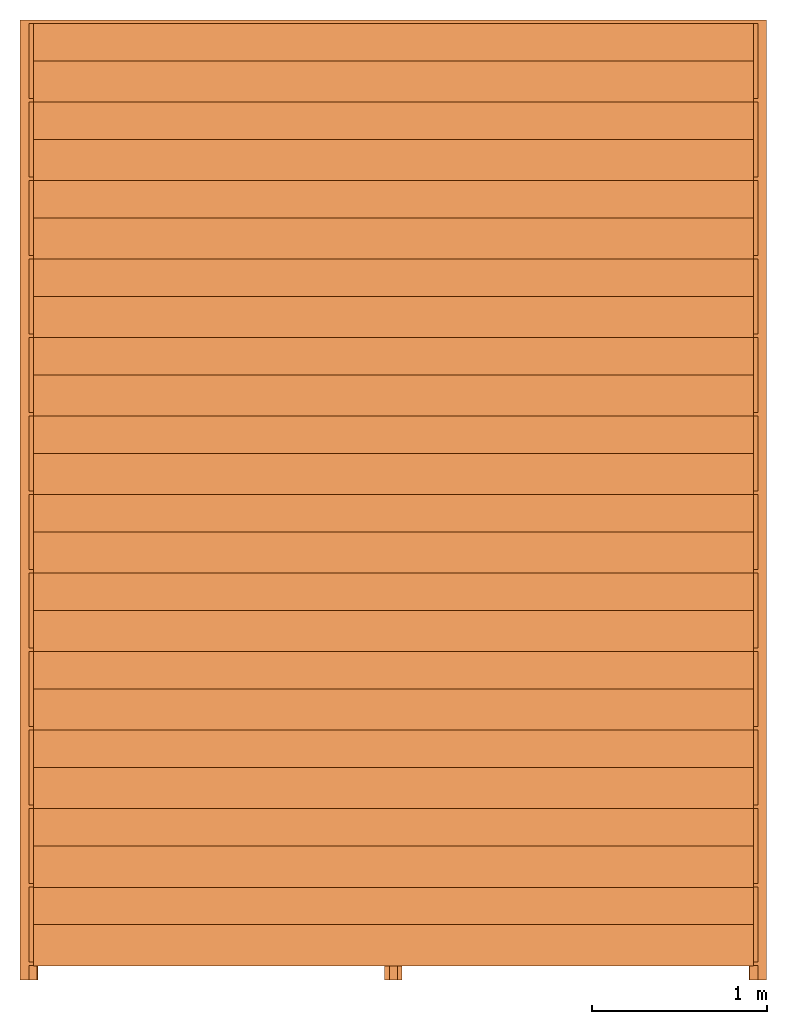
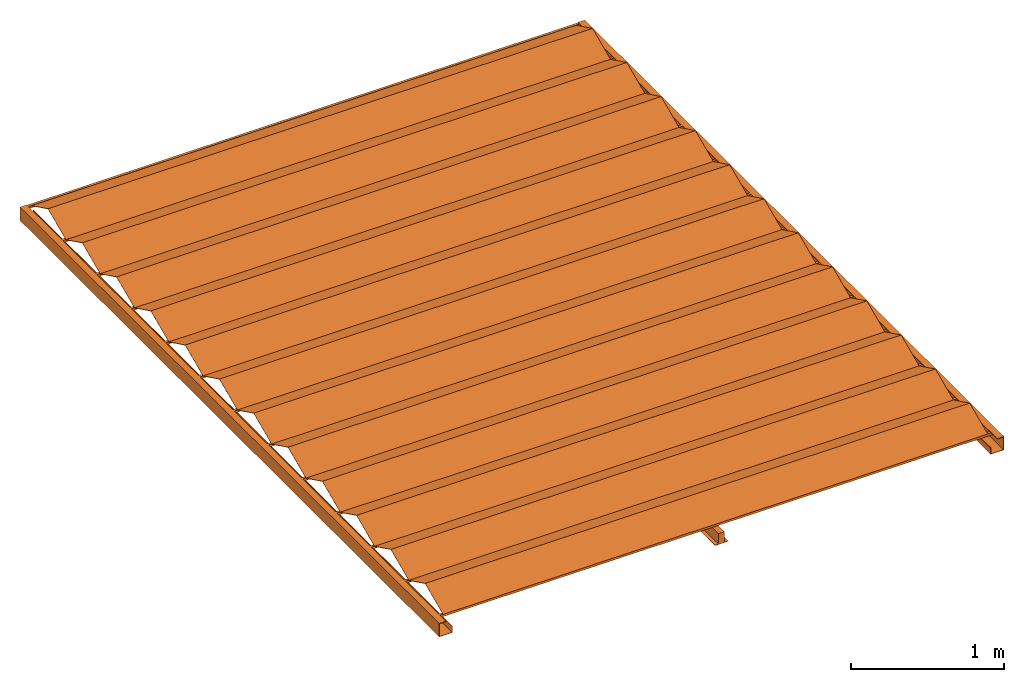
# One storey: 1 proxy.
"""IFC2X3 building model written with IfcOpenShell, lengths in feet."""

from ifc_helpers import new_model, entity, si_unit, converted_unit, derived_unit, direction, frame, frame_2d, origin, origin_2d_with_axis, place, context, subcontext, project, spatial, polyline, rectangle, outline, extrude, source, transform, mapped, material, material_list, type_object, type_shapes, element, save


model = new_model("IFC2X3")

# Units and contexts
model_context = context("Model", 3, precision=0.0001, world=origin(), true_north=direction((6.123031769111886e-17, 1.0)))
plan_context = context("Plan", 3, precision=0.0001, world=origin(), true_north=direction((6.123031769111886e-17, 1.0)))
body_context = subcontext(model_context, "Body", "Model", "MODEL_VIEW")
ifc_project = project(units=[converted_unit("LENGTHUNIT", "FOOT", entity("IfcRatioMeasure", 0.3048), si_unit("LENGTHUNIT", "METRE"), dimensions=[1, 0, 0, 0, 0, 0, 0]), converted_unit("AREAUNIT", "SQUARE FOOT", entity("IfcRatioMeasure", 0.09290304), si_unit("AREAUNIT", "SQUARE_METRE"), dimensions=[2, 0, 0, 0, 0, 0, 0]), converted_unit("VOLUMEUNIT", "CUBIC FOOT", entity("IfcRatioMeasure", 0.028316846592000004), si_unit("VOLUMEUNIT", "CUBIC_METRE"), dimensions=[3, 0, 0, 0, 0, 0, 0]), converted_unit("PLANEANGLEUNIT", "DEGREE", entity("IfcRatioMeasure", 0.017453292519943278), si_unit("PLANEANGLEUNIT", "RADIAN"), dimensions=[0, 0, 0, 0, 0, 0, 0]), si_unit("MASSUNIT", "GRAM", prefix="KILO"), derived_unit("MASSDENSITYUNIT", [(si_unit("MASSUNIT", "GRAM", prefix="KILO"), 1), (si_unit("LENGTHUNIT", "METRE"), -3)]), derived_unit("MOMENTOFINERTIAUNIT", [(si_unit("LENGTHUNIT", "METRE"), 4)]), si_unit("TIMEUNIT", "SECOND"), si_unit("FREQUENCYUNIT", "HERTZ"), si_unit("THERMODYNAMICTEMPERATUREUNIT", "DEGREE_CELSIUS"), derived_unit("THERMALTRANSMITTANCEUNIT", [(si_unit("MASSUNIT", "GRAM", prefix="KILO"), 1), (si_unit("THERMODYNAMICTEMPERATUREUNIT", "KELVIN"), -1), (si_unit("TIMEUNIT", "SECOND"), -3)]), derived_unit("VOLUMETRICFLOWRATEUNIT", [(si_unit("LENGTHUNIT", "METRE"), 3), (si_unit("TIMEUNIT", "SECOND"), -1)]), derived_unit("MASSFLOWRATEUNIT", [(si_unit("MASSUNIT", "GRAM", prefix="KILO"), 1), (si_unit("TIMEUNIT", "SECOND"), -1)]), derived_unit("ROTATIONALFREQUENCYUNIT", [(si_unit("TIMEUNIT", "SECOND"), -1)]), si_unit("ELECTRICCURRENTUNIT", "AMPERE"), si_unit("ELECTRICVOLTAGEUNIT", "VOLT"), si_unit("POWERUNIT", "WATT"), si_unit("FORCEUNIT", "NEWTON"), si_unit("ILLUMINANCEUNIT", "LUX"), si_unit("LUMINOUSFLUXUNIT", "LUMEN"), si_unit("LUMINOUSINTENSITYUNIT", "CANDELA"), derived_unit("USERDEFINED", [(si_unit("MASSUNIT", "GRAM", prefix="KILO"), -1), (si_unit("LENGTHUNIT", "METRE"), -2), (si_unit("TIMEUNIT", "SECOND"), 3), (si_unit("LUMINOUSFLUXUNIT", "LUMEN"), 1)]), derived_unit("SOUNDPOWERUNIT", [(si_unit("MASSUNIT", "GRAM", prefix="KILO"), 1), (si_unit("LENGTHUNIT", "METRE"), 2), (si_unit("TIMEUNIT", "SECOND"), -3)]), derived_unit("LINEARVELOCITYUNIT", [(si_unit("LENGTHUNIT", "METRE"), 1), (si_unit("TIMEUNIT", "SECOND"), -1)]), si_unit("PRESSUREUNIT", "PASCAL"), derived_unit("USERDEFINED", [(si_unit("LENGTHUNIT", "METRE"), -2), (si_unit("MASSUNIT", "GRAM", prefix="KILO"), 1), (si_unit("TIMEUNIT", "SECOND"), -2)]), derived_unit("LINEARFORCEUNIT", [(si_unit("MASSUNIT", "GRAM", prefix="KILO"), 1), (si_unit("LENGTHUNIT", "METRE"), 1), (si_unit("TIMEUNIT", "SECOND"), -2), (si_unit("LENGTHUNIT", "METRE"), -1)]), derived_unit("PLANARFORCEUNIT", [(si_unit("MASSUNIT", "GRAM", prefix="KILO"), 1), (si_unit("LENGTHUNIT", "METRE"), 1), (si_unit("TIMEUNIT", "SECOND"), -2), (si_unit("LENGTHUNIT", "METRE"), -2)])], contexts=[model_context, plan_context])

# Site, building, storey
site_placement = place(None, origin())
site = spatial("IfcSite", under=ifc_project, at=site_placement, CompositionType="ELEMENT")
building_placement = place(site_placement, origin())
building = spatial("IfcBuilding", under=site, at=building_placement, CompositionType="ELEMENT")
storey_placement = place(building_placement, origin())
storey = spatial("IfcBuildingStorey", under=building, at=storey_placement, Name="Level 1", CompositionType="ELEMENT", Elevation=0.0)

# Proxy
ifc_material_1 = material()
ifc_material_2 = material()
ifc_material_list_1 = material_list([ifc_material_1, ifc_material_2, ifc_material_1, ifc_material_2, ifc_material_1, ifc_material_2, ifc_material_1, ifc_material_2, ifc_material_1, ifc_material_2, ifc_material_1, ifc_material_2, ifc_material_1, ifc_material_2, ifc_material_1, ifc_material_2, ifc_material_1, ifc_material_2, ifc_material_1, ifc_material_2, ifc_material_1, ifc_material_2, ifc_material_1, ifc_material_2, ifc_material_2, ifc_material_2, ifc_material_2, ifc_material_2])
ifc_material_list_2 = material_list([ifc_material_1, ifc_material_2, ifc_material_1, ifc_material_2, ifc_material_1, ifc_material_2, ifc_material_1, ifc_material_2, ifc_material_1, ifc_material_2, ifc_material_1, ifc_material_2, ifc_material_1, ifc_material_2, ifc_material_1, ifc_material_2, ifc_material_1, ifc_material_2, ifc_material_1, ifc_material_2, ifc_material_1, ifc_material_2, ifc_material_1, ifc_material_2, ifc_material_2, ifc_material_2, ifc_material_2, ifc_material_2])
building_element_proxy_type = type_object("IfcBuildingElementProxyType", PredefinedType="NOTDEFINED", material=ifc_material_list_2)
shared_shape = source(origin(), body_context, "Body", "SweptSolid", [
    extrude(outline(polyline([(-0.7001986100476966, -0.21759078165803536), (0.08046325622011191, -0.21759078165803528), (0.623046969307386, 0.43040217737248015), (0.6000115258931665, 0.41912172771638906), (0.07559791665811669, -0.20717117088639897), (-0.6789210580310868, -0.2071711708863988), (-0.7001986100476966, -0.21759078165803536)])), frame((-6.74999999999999, -11.51283664291612, 10.456278180289173), z_axis=(1.0, 0.0, 0.0), x_axis=(0.0, -0.8980968421754009, 0.4397977513296005)), (0.0, 0.0, 1.0), 13.499999999999996),
    extrude(rectangle(XDim=0.06250000000000533, YDim=13.749999999999996, at=origin_2d_with_axis()), frame((0.0, -12.225694444444656, 10.281249999999586), z_axis=(0.0, 0.0, 1.0), x_axis=(0.0, 1.0, 0.0)), (0.0, 0.0, 1.0), 0.06249999999997513),
    extrude(outline(polyline([(-0.7001986100476966, -0.21759078165803536), (0.08046325622011191, -0.21759078165803528), (0.623046969307386, 0.43040217737248015), (0.6000115258931665, 0.41912172771638906), (0.07559791665811669, -0.20717117088639897), (-0.6789210580310868, -0.2071711708863988), (-0.7001986100476966, -0.21759078165803536)])), frame((-6.74999999999998, -10.040614420693899, 10.456278180289173), z_axis=(1.0, 0.0, 0.0), x_axis=(0.0, -0.8980968421754009, 0.4397977513296005)), (0.0, 0.0, 1.0), 13.499999999999996),
    extrude(rectangle(XDim=0.06250000000000533, YDim=13.749999999999996, at=origin_2d_with_axis()), frame((0.0, -10.753472222222435, 10.281249999999586), z_axis=(0.0, 0.0, 1.0), x_axis=(0.0, 1.0, 0.0)), (0.0, 0.0, 1.0), 0.06249999999997513),
    extrude(outline(polyline([(-0.700198610047696, -0.21759078165803453), (0.0804632562201134, -0.2175907816580345), (0.6230469693073879, 0.4304021773724805), (0.6000115258931682, 0.4191217277163894), (0.07559791665811817, -0.20717117088639825), (-0.6789210580310863, -0.20717117088639797), (-0.700198610047696, -0.21759078165803453)])), frame((-6.749999999999969, -8.568392198471676, 10.456278180289173), z_axis=(1.0, 0.0, 0.0), x_axis=(0.0, -0.8980968421754011, 0.43979775132960003)), (0.0, 0.0, 1.0), 13.499999999999996),
    extrude(rectangle(XDim=0.06250000000000533, YDim=13.749999999999996, at=origin_2d_with_axis()), frame((0.0, -9.281250000000213, 10.281249999999586), z_axis=(0.0, 0.0, 1.0), x_axis=(0.0, 1.0, 0.0)), (0.0, 0.0, 1.0), 0.06249999999997513),
    extrude(outline(polyline([(-0.7001986100476976, -0.21759078165803528), (0.0804632562201118, -0.21759078165803533), (0.623046969307387, 0.4304021773724801), (0.6000115258931675, 0.419121727716389), (0.07559791665811658, -0.20717117088639905), (-0.6789210580310878, -0.20717117088639872), (-0.7001986100476976, -0.21759078165803528)])), frame((-6.749999999999959, -7.0961699762494606, 10.456278180289173), z_axis=(1.0, 0.0, 0.0), x_axis=(0.0, -0.8980968421754011, 0.43979775132960003)), (0.0, 0.0, 1.0), 13.499999999999996),
    extrude(rectangle(XDim=0.06250000000000533, YDim=13.749999999999996, at=origin_2d_with_axis()), frame((0.0, -7.809027777777992, 10.281249999999586), z_axis=(0.0, 0.0, 1.0), x_axis=(0.0, 1.0, 0.0)), (0.0, 0.0, 1.0), 0.06249999999997513),
    extrude(outline(polyline([(-0.7001986100476976, -0.21759078165803528), (0.0804632562201118, -0.21759078165803533), (0.623046969307387, 0.4304021773724801), (0.6000115258931675, 0.419121727716389), (0.07559791665811658, -0.20717117088639905), (-0.6789210580310878, -0.20717117088639872), (-0.7001986100476976, -0.21759078165803528)])), frame((-6.749999999999948, -5.623947754027239, 10.456278180289173), z_axis=(1.0, 0.0, 0.0), x_axis=(0.0, -0.8980968421754011, 0.43979775132960003)), (0.0, 0.0, 1.0), 13.499999999999996),
    extrude(rectangle(XDim=0.06250000000000533, YDim=13.749999999999996, at=origin_2d_with_axis()), frame((0.0, -6.336805555555774, 10.281249999999586), z_axis=(0.0, 0.0, 1.0), x_axis=(0.0, 1.0, 0.0)), (0.0, 0.0, 1.0), 0.06249999999997513),
    extrude(outline(polyline([(-0.7001986100476967, -0.2175907816580349), (0.0804632562201126, -0.21759078165803492), (0.6230469693073879, 0.43040217737248054), (0.6000115258931682, 0.41912172771638945), (0.07559791665811738, -0.20717117088639866), (-0.6789210580310869, -0.20717117088639833), (-0.7001986100476967, -0.2175907816580349)])), frame((-6.749999999999938, -4.151725531805019, 10.456278180289173), z_axis=(1.0, 0.0, 0.0), x_axis=(0.0, -0.8980968421754011, 0.43979775132960003)), (0.0, 0.0, 1.0), 13.499999999999996),
    extrude(rectangle(XDim=0.06250000000000533, YDim=13.749999999999996, at=origin_2d_with_axis()), frame((0.0, -4.864583333333552, 10.281249999999586), z_axis=(0.0, 0.0, 1.0), x_axis=(0.0, 1.0, 0.0)), (0.0, 0.0, 1.0), 0.06249999999997513),
    extrude(outline(polyline([(-0.7001986100476967, -0.2175907816580349), (0.0804632562201126, -0.21759078165803492), (0.6230469693073879, 0.43040217737248054), (0.600011525893168, 0.4191217277163892), (0.07559791665811777, -0.20717117088639847), (-0.6789210580310867, -0.20717117088639822), (-0.7001986100476967, -0.2175907816580349)])), frame((-6.74999999999993, -2.6795033095828, 10.456278180289173), z_axis=(1.0, 0.0, 0.0), x_axis=(0.0, -0.8980968421754011, 0.43979775132960003)), (0.0, 0.0, 1.0), 13.499999999999996),
    extrude(rectangle(XDim=0.06250000000000488, YDim=13.749999999999996, at=frame_2d((-2.220446049250313e-16, 0.0), x_axis=(1.0, 0.0))), frame((0.0, -3.392361111111333, 10.281249999999586), z_axis=(0.0, 0.0, 1.0), x_axis=(0.0, 1.0, 0.0)), (0.0, 0.0, 1.0), 0.06249999999997513),
    extrude(outline(polyline([(-0.7001986100476971, -0.217590781658035), (0.08046325622011222, -0.21759078165803514), (0.6230469693073873, 0.4304021773724803), (0.6000115258931674, 0.419121727716389), (0.07559791665811719, -0.20717117088639875), (-0.6789210580310873, -0.20717117088639844), (-0.7001986100476971, -0.217590781658035)])), frame((-6.749999999999919, -1.2072810873605806, 10.456278180289173), z_axis=(1.0, 0.0, 0.0), x_axis=(0.0, -0.8980968421754011, 0.4397977513296001)), (0.0, 0.0, 1.0), 13.499999999999993),
    extrude(rectangle(XDim=0.06250000000000488, YDim=13.749999999999996, at=frame_2d((-2.220446049250313e-16, 0.0), x_axis=(1.0, 0.0))), frame((0.0, -1.9201388888891135, 10.281249999999586), z_axis=(0.0, 0.0, 1.0), x_axis=(0.0, 1.0, 0.0)), (0.0, 0.0, 1.0), 0.06249999999997513),
    extrude(outline(polyline([(-0.7001986100476971, -0.21759078165803525), (0.08046325622011212, -0.21759078165803514), (0.6230469693073871, 0.4304021773724804), (0.6000115258931673, 0.4191217277163891), (0.07559791665811709, -0.20717117088639878), (-0.6789210580310873, -0.20717117088639864), (-0.7001986100476971, -0.21759078165803525)])), frame((-6.749999999999909, 0.2649411348616403, 10.456278180289173), z_axis=(1.0, 0.0, 0.0), x_axis=(0.0, -0.8980968421754011, 0.4397977513296001)), (0.0, 0.0, 1.0), 13.499999999999996),
    extrude(rectangle(XDim=0.06250000000000488, YDim=13.749999999999996, at=origin_2d_with_axis()), frame((0.0, -0.4479166666668932, 10.281249999999586), z_axis=(0.0, 0.0, 1.0), x_axis=(0.0, 1.0, 0.0)), (0.0, 0.0, 1.0), 0.06249999999997513),
    extrude(outline(polyline([(-0.7001986100476973, -0.21759078165803536), (0.080463256220112, -0.2175907816580352), (0.623046969307387, 0.4304021773724803), (0.6000115258931673, 0.41912172771638906), (0.07559791665811698, -0.20717117088639883), (-0.6789210580310876, -0.2071711708863988), (-0.7001986100476973, -0.21759078165803536)])), frame((-6.749999999999899, 1.7371633570838612, 10.456278180289173), z_axis=(1.0, 0.0, 0.0), x_axis=(0.0, -0.8980968421754011, 0.43979775132960003)), (0.0, 0.0, 1.0), 13.499999999999996),
    extrude(rectangle(XDim=0.06250000000000488, YDim=13.749999999999996, at=origin_2d_with_axis()), frame((0.0, 1.0243055555553282, 10.281249999999586), z_axis=(0.0, 0.0, 1.0), x_axis=(0.0, 1.0, 0.0)), (0.0, 0.0, 1.0), 0.06249999999997513),
    extrude(outline(polyline([(-0.7001986100476966, -0.21759078165803536), (0.08046325622011191, -0.21759078165803528), (0.623046969307386, 0.43040217737248015), (0.6000115258931665, 0.41912172771638906), (0.07559791665811669, -0.20717117088639897), (-0.6789210580310868, -0.2071711708863988), (-0.7001986100476966, -0.21759078165803536)])), frame((-6.75000000000003, -12.985058865138338, 10.456278180289173), z_axis=(1.0, 0.0, 0.0), x_axis=(0.0, -0.8980968421754009, 0.4397977513296005)), (0.0, 0.0, 1.0), 13.499999999999996),
    extrude(rectangle(XDim=0.06250000000000533, YDim=13.749999999999996, at=origin_2d_with_axis()), frame((0.0, -13.69791666666687, 10.281249999999586), z_axis=(0.0, 0.0, 1.0), x_axis=(0.0, 1.0, 0.0)), (0.0, 0.0, 1.0), 0.06249999999997513),
    extrude(outline(polyline([(-0.7001986100476971, -0.21759078165803505), (0.0804632562201122, -0.21759078165803514), (0.6230469693073875, 0.4304021773724803), (0.6000115258931675, 0.419121727716389), (0.07559791665811738, -0.20717117088639866), (-0.6789210580310874, -0.20717117088639855), (-0.7001986100476971, -0.21759078165803505)])), frame((-6.749999999999886, 3.209385579306082, 10.456278180289173), z_axis=(1.0, 0.0, 0.0), x_axis=(0.0, -0.8980968421754011, 0.43979775132960003)), (0.0, 0.0, 1.0), 13.499999999999996),
    extrude(rectangle(XDim=0.06250000000000488, YDim=13.749999999999996, at=frame_2d((-2.220446049250313e-16, 0.0), x_axis=(1.0, 0.0))), frame((0.0, 2.4965277777775485, 10.281249999999586), z_axis=(0.0, 0.0, 1.0), x_axis=(0.0, 1.0, 0.0)), (0.0, 0.0, 1.0), 0.06249999999997513),
    extrude(rectangle(XDim=13.750000000000002, YDim=0.06249999999999556, at=origin_2d_with_axis()), frame((0.0, 3.9687499999997478, 10.281249999999577), z_axis=(0.0, 0.0, 1.0), x_axis=(-1.0, 0.0, 0.0)), (0.0, 0.0, 1.0), 0.06249999999999645),
    extrude(outline(polyline([(-0.1666666666665355, -0.17499999999998117), (0.16666666666657282, -0.17499999999998117), (0.16666666666657282, -0.008333333333368387), (0.15624999999990496, -0.008333333333368387), (0.15624999999990496, -0.16458333333340747), (-0.15624999999986766, -0.16458333333340747), (-0.15624999999986766, 0.1687500000000508), (0.0, 0.1687500000000508), (0.0, 0.17916666666671688), (-0.1666666666665355, 0.17916666666671688), (-0.1666666666665355, -0.17499999999998117)])), frame((6.833333333333591, -14.0, 10.174999999999756), z_axis=(0.0, 1.0, 0.0), x_axis=(-1.0, 0.0, 0.0)), (0.0, 0.0, 1.0), 18.000000000000064),
    extrude(outline(polyline([(-0.16666666666660346, -0.07552083333334281), (0.16666666666673224, -0.07552083333334281), (0.16666666666673224, -0.06510416666667673), (0.07416666666660321, -0.06510416666667673), (0.07416666666660321, 0.20572916666667496), (-0.074166666666732, 0.20572916666667496), (-0.074166666666732, -0.06510416666666252), (-0.16666666666660346, -0.06510416666666252), (-0.16666666666660346, -0.07552083333334281)])), frame((0.0, -14.0, 10.075520833333117), z_axis=(0.0, 1.0, 0.0), x_axis=(-1.0, 0.0, 0.0)), (0.0, 0.0, 1.0), 18.000000000000064),
    extrude(outline(polyline([(-0.17499999999999538, -0.1666666666666643), (0.17916666666670267, -0.1666666666666643), (0.17916666666670267, 0.0), (0.1687500000000366, 0.0), (0.1687500000000366, -0.15624999999999734), (-0.16458333333342345, -0.15624999999999734), (-0.16458333333342345, 0.15624999999999467), (-0.008333333333329307, 0.15624999999999467), (-0.008333333333329307, 0.16666666666666163), (-0.17499999999999538, 0.16666666666666163), (-0.17499999999999538, -0.1666666666666643)])), frame((-6.833333333333177, -14.0, 10.17499999999977), z_axis=(0.0, 1.0, 0.0), x_axis=(0.0, 0.0, 1.0)), (0.0, 0.0, 1.0), 18.000000000000064),
])
type_shapes(building_element_proxy_type, [shared_shape])
proxy_placement = place(storey_placement, frame((0.0, -4.0, 0.0)))
element("IfcBuildingElementProxy", 1, at=proxy_placement, inside=storey, type_object=building_element_proxy_type, material=ifc_material_list_1, context=body_context, shape_type="MappedRepresentation", body=[
    mapped(shared_shape, transform((0.0, 0.0, 0.0), scale=1.0)),
])

save(model, "model.ifc")
